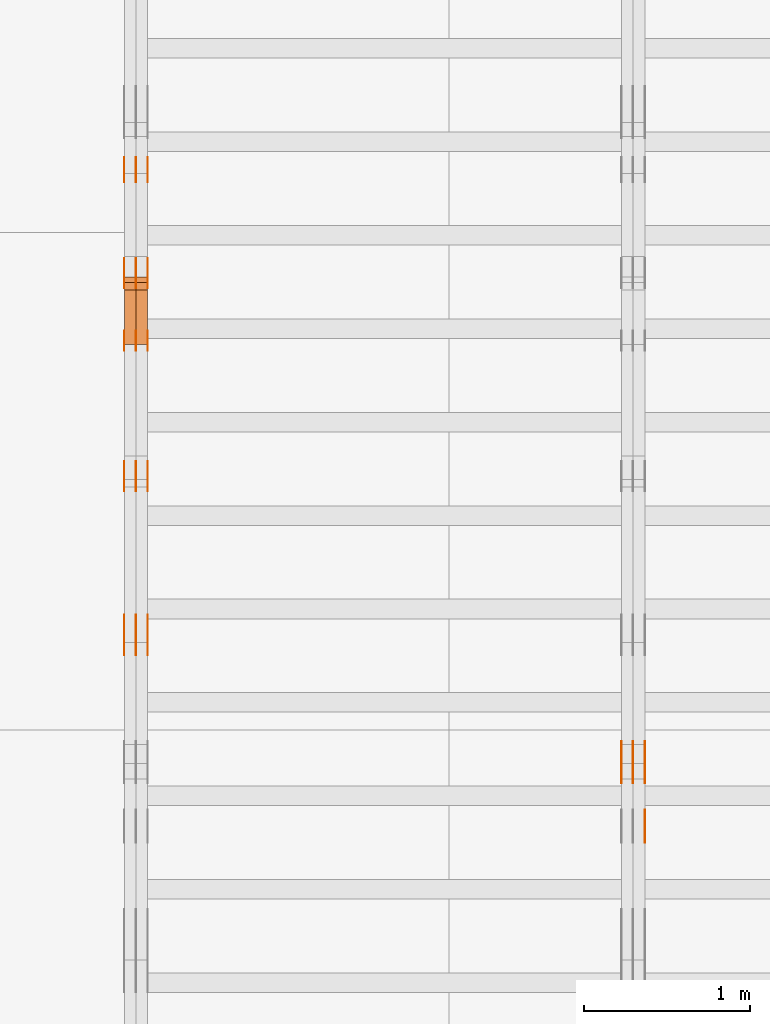
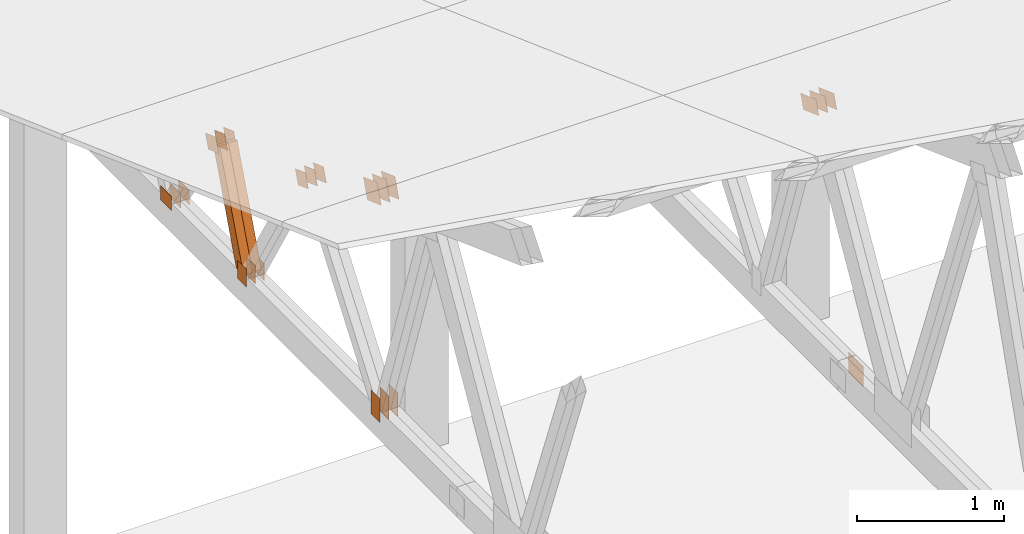
# One storey, part 111 of 189: 31 proxies.
"""IFC2X3 building model written with IfcOpenShell, lengths in millimetres."""

from ifc_helpers import new_model, entity, si_unit, converted_unit, derived_unit, direction, frame, frame_2d, origin, origin_2d_with_axis, place, context, subcontext, project, spatial, polyline, rectangle, outline, extrude, source, transform, mapped, material, type_object, type_shapes, element, save


model = new_model("IFC2X3")

# Units and contexts
model_context = context("Model", 3, precision=0.01, world=origin(), true_north=direction((6.12303176911189e-17, 1.0)))
body_context = subcontext(model_context, "Body", "Model", "MODEL_VIEW")
ifc_project = project(units=[si_unit("LENGTHUNIT", "METRE", prefix="MILLI"), si_unit("AREAUNIT", "SQUARE_METRE"), si_unit("VOLUMEUNIT", "CUBIC_METRE"), converted_unit("PLANEANGLEUNIT", "DEGREE", entity("IfcRatioMeasure", 0.0174532925199433), si_unit("PLANEANGLEUNIT", "RADIAN"), dimensions=[0, 0, 0, 0, 0, 0, 0]), si_unit("MASSUNIT", "GRAM", prefix="KILO"), derived_unit("MASSDENSITYUNIT", [(si_unit("MASSUNIT", "GRAM", prefix="KILO"), 1), (si_unit("LENGTHUNIT", "METRE"), -3)]), si_unit("TIMEUNIT", "SECOND"), si_unit("FREQUENCYUNIT", "HERTZ"), si_unit("THERMODYNAMICTEMPERATUREUNIT", "DEGREE_CELSIUS"), derived_unit("THERMALTRANSMITTANCEUNIT", [(si_unit("MASSUNIT", "GRAM", prefix="KILO"), 1), (si_unit("THERMODYNAMICTEMPERATUREUNIT", "KELVIN"), -1), (si_unit("TIMEUNIT", "SECOND"), -3)]), derived_unit("VOLUMETRICFLOWRATEUNIT", [(si_unit("LENGTHUNIT", "METRE"), 3), (si_unit("TIMEUNIT", "SECOND"), -1)]), si_unit("ELECTRICCURRENTUNIT", "AMPERE"), si_unit("ELECTRICVOLTAGEUNIT", "VOLT"), si_unit("POWERUNIT", "WATT"), si_unit("FORCEUNIT", "NEWTON"), si_unit("ILLUMINANCEUNIT", "LUX"), si_unit("LUMINOUSFLUXUNIT", "LUMEN"), si_unit("LUMINOUSINTENSITYUNIT", "CANDELA"), derived_unit("USERDEFINED", [(si_unit("MASSUNIT", "GRAM", prefix="KILO"), -1), (si_unit("LENGTHUNIT", "METRE"), -2), (si_unit("TIMEUNIT", "SECOND"), 3), (si_unit("LUMINOUSFLUXUNIT", "LUMEN"), 1)]), derived_unit("LINEARVELOCITYUNIT", [(si_unit("LENGTHUNIT", "METRE"), 1), (si_unit("TIMEUNIT", "SECOND"), -1)]), si_unit("PRESSUREUNIT", "PASCAL"), derived_unit("USERDEFINED", [(si_unit("LENGTHUNIT", "METRE"), -2), (si_unit("MASSUNIT", "GRAM", prefix="KILO"), 1), (si_unit("TIMEUNIT", "SECOND"), -2)])], contexts=[model_context])

# Site, building, storey
site_placement = place(None, origin())
site = spatial("IfcSite", under=ifc_project, at=site_placement, CompositionType="ELEMENT")
building_placement = place(site_placement, origin())
building = spatial("IfcBuilding", under=site, at=building_placement, CompositionType="ELEMENT")
storey_placement = place(building_placement, origin())
storey = spatial("IfcBuildingStorey", under=building, at=storey_placement, Name="Default", CompositionType="ELEMENT", Elevation=0.0)

# Proxies
ifc_material_1 = material(Name="IfcSurfaceStyle #27528")
building_element_proxy_type_1 = type_object("IfcBuildingElementProxyType", PredefinedType="NOTDEFINED", material=ifc_material_1)
shared_shape_1 = source(origin(), body_context, "Body", "SweptSolid", [
    extrude(outline(polyline([(-112.499846801582, -59.999986193028), (112.499924372729, -59.999986193028), (112.499888552087, 59.999986193028), (-112.499966123235, 59.999986193028), (-112.499846801582, -59.999986193028)])), frame((112.499989807712, 60.0001003787081, 0.0), z_axis=(0.0, 0.0, 1.0), x_axis=(-1.0, 0.0, 0.0)), (0.0, 0.0, 1.0), 1.3),
])
type_shapes(building_element_proxy_type_1, [shared_shape_1])
proxy_1_placement = place(building_placement, frame((3336.3, 24040.8868138992, 2049.61031693104), z_axis=(-1.0, 0.0, 0.0), x_axis=(0.0, -0.939692620785908, 0.342020143325669)))
element("IfcBuildingElementProxy", 1, at=proxy_1_placement, inside=storey, type_object=building_element_proxy_type_1, material=ifc_material_1, context=body_context, shape_type="MappedRepresentation", body=[
    mapped(shared_shape_1, transform((0.0, 0.0, 0.0), scale=1.0)),
])
ifc_material_2 = material(Name="IfcSurfaceStyle #27471")
building_element_proxy_type_2 = type_object("IfcBuildingElementProxyType", PredefinedType="NOTDEFINED", material=ifc_material_2)
shared_shape_2 = source(origin(), body_context, "Body", "SweptSolid", [
    extrude(outline(polyline([(-112.499846801582, -59.999986193028), (112.499924372729, -59.999986193028), (112.499888552087, 59.999986193028), (-112.499966123235, 59.999986193028), (-112.499846801582, -59.999986193028)])), frame((112.499989807712, 60.0001003787081, 0.0), z_axis=(0.0, 0.0, 1.0), x_axis=(-1.0, 0.0, 0.0)), (0.0, 0.0, 1.0), 1.29999999999998),
])
type_shapes(building_element_proxy_type_2, [shared_shape_2])
proxy_2_placement = place(building_placement, frame((3265.0, 24040.8868138992, 2049.61031693104), z_axis=(-1.0, 0.0, 0.0), x_axis=(0.0, -0.939692620785908, 0.342020143325669)))
element("IfcBuildingElementProxy", 2, at=proxy_2_placement, inside=storey, type_object=building_element_proxy_type_2, material=ifc_material_2, context=body_context, shape_type="MappedRepresentation", body=[
    mapped(shared_shape_2, transform((0.0, 0.0, 0.0), scale=1.0)),
])
ifc_material_3 = material(Name="IfcSurfaceStyle #27414")
building_element_proxy_type_3 = type_object("IfcBuildingElementProxyType", PredefinedType="NOTDEFINED", material=ifc_material_3)
shared_shape_3 = source(origin(), body_context, "Body", "SweptSolid", [
    extrude(outline(polyline([(-112.499846801582, -59.999986193028), (112.499924372729, -59.999986193028), (112.499888552087, 59.999986193028), (-112.499966123235, 59.999986193028), (-112.499846801582, -59.999986193028)])), frame((112.499989807712, 60.0001003787081, 0.0), z_axis=(0.0, 0.0, 1.0), x_axis=(-1.0, 0.0, 0.0)), (0.0, 0.0, 1.0), 1.29999999999998),
])
type_shapes(building_element_proxy_type_3, [shared_shape_3])
proxy_3_placement = place(building_placement, frame((3266.3, 24040.8868138992, 2049.61031693104), z_axis=(-1.0, 0.0, 0.0), x_axis=(0.0, -0.939692620785908, 0.342020143325669)))
element("IfcBuildingElementProxy", 3, at=proxy_3_placement, inside=storey, type_object=building_element_proxy_type_3, material=ifc_material_3, context=body_context, shape_type="MappedRepresentation", body=[
    mapped(shared_shape_3, transform((0.0, 0.0, 0.0), scale=1.0)),
])
ifc_material_4 = material(Name="IfcSurfaceStyle #27357")
building_element_proxy_type_4 = type_object("IfcBuildingElementProxyType", PredefinedType="NOTDEFINED", material=ifc_material_4)
shared_shape_4 = source(origin(), body_context, "Body", "SweptSolid", [
    extrude(outline(polyline([(-112.499846801582, -59.999986193028), (112.499924372729, -59.999986193028), (112.499888552087, 59.999986193028), (-112.499966123235, 59.999986193028), (-112.499846801582, -59.999986193028)])), frame((112.499989807712, 60.0001003787081, 0.0), z_axis=(0.0, 0.0, 1.0), x_axis=(-1.0, 0.0, 0.0)), (0.0, 0.0, 1.0), 1.29999999999999),
])
type_shapes(building_element_proxy_type_4, [shared_shape_4])
proxy_4_placement = place(building_placement, frame((3195.0, 24040.8868138992, 2049.61031693104), z_axis=(-1.0, 0.0, 0.0), x_axis=(0.0, -0.939692620785908, 0.342020143325669)))
element("IfcBuildingElementProxy", 4, at=proxy_4_placement, inside=storey, type_object=building_element_proxy_type_4, material=ifc_material_4, context=body_context, shape_type="MappedRepresentation", body=[
    mapped(shared_shape_4, transform((0.0, 0.0, 0.0), scale=1.0)),
])
ifc_material_5 = material(Name="IfcSurfaceStyle #23652")
building_element_proxy_type_5 = type_object("IfcBuildingElementProxyType", PredefinedType="NOTDEFINED", material=ifc_material_5)
shared_shape_5 = source(origin(), body_context, "Body", "SweptSolid", [
    extrude(rectangle(XDim=200.0, YDim=168.0, at=origin_2d_with_axis()), frame((100.0, 84.0, 0.0), z_axis=(0.0, 0.0, 1.0), x_axis=(-1.0, 0.0, 0.0)), (0.0, 0.0, 1.0), 1.3),
])
type_shapes(building_element_proxy_type_5, [shared_shape_5])
proxy_5_placement = place(building_placement, frame((3336.3, 23470.0, 206.5), z_axis=(-1.0, 0.0, 0.0), x_axis=(0.0, 1.0, 0.0)))
element("IfcBuildingElementProxy", 5, at=proxy_5_placement, inside=storey, type_object=building_element_proxy_type_5, material=ifc_material_5, context=body_context, shape_type="MappedRepresentation", body=[
    mapped(shared_shape_5, transform((0.0, 0.0, 0.0), scale=1.0)),
])
ifc_material_6 = material(Name="IfcSurfaceStyle #11507")
building_element_proxy_type_6 = type_object("IfcBuildingElementProxyType", PredefinedType="NOTDEFINED", material=ifc_material_6)
shared_shape_6 = source(origin(), body_context, "Body", "SweptSolid", [
    extrude(rectangle(XDim=200.0, YDim=120.0, at=origin_2d_with_axis()), frame((100.0, 60.0002296775929, 0.0), z_axis=(0.0, 0.0, 1.0), x_axis=(-1.0, 0.0, 0.0)), (0.0, 0.0, 1.0), 1.3),
])
type_shapes(building_element_proxy_type_6, [shared_shape_6])
proxy_6_placement = place(building_placement, frame((336.3, 24619.3435203224, 145.0), z_axis=(-1.0, 0.0, 0.0), x_axis=(0.0, 0.0, 1.0)))
element("IfcBuildingElementProxy", 6, at=proxy_6_placement, inside=storey, type_object=building_element_proxy_type_6, material=ifc_material_6, context=body_context, shape_type="MappedRepresentation", body=[
    mapped(shared_shape_6, transform((0.0, 0.0, 0.0), scale=1.0)),
])
ifc_material_7 = material(Name="IfcSurfaceStyle #11450")
building_element_proxy_type_7 = type_object("IfcBuildingElementProxyType", PredefinedType="NOTDEFINED", material=ifc_material_7)
shared_shape_7 = source(origin(), body_context, "Body", "SweptSolid", [
    extrude(rectangle(XDim=200.0, YDim=120.0, at=origin_2d_with_axis()), frame((100.0, 60.0002296775929, 0.0), z_axis=(0.0, 0.0, 1.0), x_axis=(-1.0, 0.0, 0.0)), (0.0, 0.0, 1.0), 1.29999999999998),
])
type_shapes(building_element_proxy_type_7, [shared_shape_7])
proxy_7_placement = place(building_placement, frame((265.0, 24619.3435203224, 145.0), z_axis=(-1.0, 0.0, 0.0), x_axis=(0.0, 0.0, 1.0)))
element("IfcBuildingElementProxy", 7, at=proxy_7_placement, inside=storey, type_object=building_element_proxy_type_7, material=ifc_material_7, context=body_context, shape_type="MappedRepresentation", body=[
    mapped(shared_shape_7, transform((0.0, 0.0, 0.0), scale=1.0)),
])
ifc_material_8 = material(Name="IfcSurfaceStyle #11393")
building_element_proxy_type_8 = type_object("IfcBuildingElementProxyType", PredefinedType="NOTDEFINED", material=ifc_material_8)
shared_shape_8 = source(origin(), body_context, "Body", "SweptSolid", [
    extrude(rectangle(XDim=200.0, YDim=120.0, at=origin_2d_with_axis()), frame((100.0, 60.0002296775929, 0.0), z_axis=(0.0, 0.0, 1.0), x_axis=(-1.0, 0.0, 0.0)), (0.0, 0.0, 1.0), 1.29999999999998),
])
type_shapes(building_element_proxy_type_8, [shared_shape_8])
proxy_8_placement = place(building_placement, frame((266.3, 24619.3435203224, 145.0), z_axis=(-1.0, 0.0, 0.0), x_axis=(0.0, 0.0, 1.0)))
element("IfcBuildingElementProxy", 8, at=proxy_8_placement, inside=storey, type_object=building_element_proxy_type_8, material=ifc_material_8, context=body_context, shape_type="MappedRepresentation", body=[
    mapped(shared_shape_8, transform((0.0, 0.0, 0.0), scale=1.0)),
])
ifc_material_9 = material(Name="IfcSurfaceStyle #11336")
building_element_proxy_type_9 = type_object("IfcBuildingElementProxyType", PredefinedType="NOTDEFINED", material=ifc_material_9)
shared_shape_9 = source(origin(), body_context, "Body", "SweptSolid", [
    extrude(rectangle(XDim=200.0, YDim=120.0, at=origin_2d_with_axis()), frame((100.0, 60.0002296775929, 0.0), z_axis=(0.0, 0.0, 1.0), x_axis=(-1.0, 0.0, 0.0)), (0.0, 0.0, 1.0), 1.29999999999999),
])
type_shapes(building_element_proxy_type_9, [shared_shape_9])
proxy_9_placement = place(building_placement, frame((195.0, 24619.3435203224, 145.0), z_axis=(-1.0, 0.0, 0.0), x_axis=(0.0, 0.0, 1.0)))
element("IfcBuildingElementProxy", 9, at=proxy_9_placement, inside=storey, type_object=building_element_proxy_type_9, material=ifc_material_9, context=body_context, shape_type="MappedRepresentation", body=[
    mapped(shared_shape_9, transform((0.0, 0.0, 0.0), scale=1.0)),
])
ifc_material_10 = material(Name="IfcSurfaceStyle #10823")
building_element_proxy_type_10 = type_object("IfcBuildingElementProxyType", PredefinedType="NOTDEFINED", material=ifc_material_10)
shared_shape_10 = source(origin(), body_context, "Body", "SweptSolid", [
    extrude(outline(polyline([(-74.9999475298494, -60.0), (75.0000042257432, -60.0), (74.9999684051025, 60.0), (-75.0000251009963, 60.0), (-74.9999475298494, -60.0)])), frame((75.0000607644577, 60.0000865490217, 0.0), z_axis=(0.0, 0.0, 1.0), x_axis=(-1.0, 0.0, 0.0)), (0.0, 0.0, 1.0), 1.3),
])
type_shapes(building_element_proxy_type_10, [shared_shape_10])
proxy_10_placement = place(building_placement, frame((336.3, 25732.0586805394, 1446.84420669249), z_axis=(-1.0, 0.0, 0.0), x_axis=(0.0, -0.939692620785908, 0.342020143325669)))
element("IfcBuildingElementProxy", 10, at=proxy_10_placement, inside=storey, type_object=building_element_proxy_type_10, material=ifc_material_10, context=body_context, shape_type="MappedRepresentation", body=[
    mapped(shared_shape_10, transform((0.0, 0.0, 0.0), scale=1.0)),
])
ifc_material_11 = material(Name="IfcSurfaceStyle #10766")
building_element_proxy_type_11 = type_object("IfcBuildingElementProxyType", PredefinedType="NOTDEFINED", material=ifc_material_11)
shared_shape_11 = source(origin(), body_context, "Body", "SweptSolid", [
    extrude(outline(polyline([(-74.9999475298494, -60.0), (75.0000042257432, -60.0), (74.9999684051025, 60.0), (-75.0000251009963, 60.0), (-74.9999475298494, -60.0)])), frame((75.0000607644577, 60.0000865490217, 0.0), z_axis=(0.0, 0.0, 1.0), x_axis=(-1.0, 0.0, 0.0)), (0.0, 0.0, 1.0), 1.29999999999999),
])
type_shapes(building_element_proxy_type_11, [shared_shape_11])
proxy_11_placement = place(building_placement, frame((265.0, 25732.0586805394, 1446.84420669249), z_axis=(-1.0, 0.0, 0.0), x_axis=(0.0, -0.939692620785908, 0.342020143325669)))
element("IfcBuildingElementProxy", 11, at=proxy_11_placement, inside=storey, type_object=building_element_proxy_type_11, material=ifc_material_11, context=body_context, shape_type="MappedRepresentation", body=[
    mapped(shared_shape_11, transform((0.0, 0.0, 0.0), scale=1.0)),
])
ifc_material_12 = material(Name="IfcSurfaceStyle #10709")
building_element_proxy_type_12 = type_object("IfcBuildingElementProxyType", PredefinedType="NOTDEFINED", material=ifc_material_12)
shared_shape_12 = source(origin(), body_context, "Body", "SweptSolid", [
    extrude(outline(polyline([(-74.9999475298494, -60.0), (75.0000042257432, -60.0), (74.9999684051025, 60.0), (-75.0000251009963, 60.0), (-74.9999475298494, -60.0)])), frame((75.0000607644577, 60.0000865490217, 0.0), z_axis=(0.0, 0.0, 1.0), x_axis=(-1.0, 0.0, 0.0)), (0.0, 0.0, 1.0), 1.29999999999999),
])
type_shapes(building_element_proxy_type_12, [shared_shape_12])
proxy_12_placement = place(building_placement, frame((266.3, 25732.0586805394, 1446.84420669249), z_axis=(-1.0, 0.0, 0.0), x_axis=(0.0, -0.939692620785908, 0.342020143325669)))
element("IfcBuildingElementProxy", 12, at=proxy_12_placement, inside=storey, type_object=building_element_proxy_type_12, material=ifc_material_12, context=body_context, shape_type="MappedRepresentation", body=[
    mapped(shared_shape_12, transform((0.0, 0.0, 0.0), scale=1.0)),
])
ifc_material_13 = material(Name="IfcSurfaceStyle #10652")
building_element_proxy_type_13 = type_object("IfcBuildingElementProxyType", PredefinedType="NOTDEFINED", material=ifc_material_13)
shared_shape_13 = source(origin(), body_context, "Body", "SweptSolid", [
    extrude(outline(polyline([(-74.9999475298494, -60.0), (75.0000042257432, -60.0), (74.9999684051025, 60.0), (-75.0000251009963, 60.0), (-74.9999475298494, -60.0)])), frame((75.0000607644577, 60.0000865490217, 0.0), z_axis=(0.0, 0.0, 1.0), x_axis=(-1.0, 0.0, 0.0)), (0.0, 0.0, 1.0), 1.29999999999999),
])
type_shapes(building_element_proxy_type_13, [shared_shape_13])
proxy_13_placement = place(building_placement, frame((195.0, 25732.0586805394, 1446.84420669249), z_axis=(-1.0, 0.0, 0.0), x_axis=(0.0, -0.939692620785908, 0.342020143325669)))
element("IfcBuildingElementProxy", 13, at=proxy_13_placement, inside=storey, type_object=building_element_proxy_type_13, material=ifc_material_13, context=body_context, shape_type="MappedRepresentation", body=[
    mapped(shared_shape_13, transform((0.0, 0.0, 0.0), scale=1.0)),
])
ifc_material_14 = material(Name="IfcSurfaceStyle #10595")
building_element_proxy_type_14 = type_object("IfcBuildingElementProxyType", PredefinedType="NOTDEFINED", material=ifc_material_14)
shared_shape_14 = source(origin(), body_context, "Body", "SweptSolid", [
    extrude(rectangle(XDim=150.0, YDim=120.0, at=frame_2d((-7.105427357601e-15, 0.0), x_axis=(1.0, 0.0))), frame((75.0, 60.0, 0.0), z_axis=(0.0, 0.0, 1.0), x_axis=(-1.0, 0.0, 0.0)), (0.0, 0.0, 1.0), 1.3),
])
type_shapes(building_element_proxy_type_14, [shared_shape_14])
proxy_14_placement = place(building_placement, frame((336.3, 26439.0083007813, 170.0), z_axis=(-1.0, 0.0, 0.0), x_axis=(0.0, 0.0, 1.0)))
element("IfcBuildingElementProxy", 14, at=proxy_14_placement, inside=storey, type_object=building_element_proxy_type_14, material=ifc_material_14, context=body_context, shape_type="MappedRepresentation", body=[
    mapped(shared_shape_14, transform((0.0, 0.0, 0.0), scale=1.0)),
])
ifc_material_15 = material(Name="IfcSurfaceStyle #10538")
building_element_proxy_type_15 = type_object("IfcBuildingElementProxyType", PredefinedType="NOTDEFINED", material=ifc_material_15)
shared_shape_15 = source(origin(), body_context, "Body", "SweptSolid", [
    extrude(rectangle(XDim=150.0, YDim=120.0, at=frame_2d((-7.105427357601e-15, 0.0), x_axis=(1.0, 0.0))), frame((75.0, 60.0, 0.0), z_axis=(0.0, 0.0, 1.0), x_axis=(-1.0, 0.0, 0.0)), (0.0, 0.0, 1.0), 1.29999999999999),
])
type_shapes(building_element_proxy_type_15, [shared_shape_15])
proxy_15_placement = place(building_placement, frame((265.0, 26439.0083007813, 170.0), z_axis=(-1.0, 0.0, 0.0), x_axis=(0.0, 0.0, 1.0)))
element("IfcBuildingElementProxy", 15, at=proxy_15_placement, inside=storey, type_object=building_element_proxy_type_15, material=ifc_material_15, context=body_context, shape_type="MappedRepresentation", body=[
    mapped(shared_shape_15, transform((0.0, 0.0, 0.0), scale=1.0)),
])
ifc_material_16 = material(Name="IfcSurfaceStyle #10481")
building_element_proxy_type_16 = type_object("IfcBuildingElementProxyType", PredefinedType="NOTDEFINED", material=ifc_material_16)
shared_shape_16 = source(origin(), body_context, "Body", "SweptSolid", [
    extrude(rectangle(XDim=150.0, YDim=120.0, at=frame_2d((-7.105427357601e-15, 0.0), x_axis=(1.0, 0.0))), frame((75.0, 60.0, 0.0), z_axis=(0.0, 0.0, 1.0), x_axis=(-1.0, 0.0, 0.0)), (0.0, 0.0, 1.0), 1.29999999999999),
])
type_shapes(building_element_proxy_type_16, [shared_shape_16])
proxy_16_placement = place(building_placement, frame((266.3, 26439.0083007813, 170.0), z_axis=(-1.0, 0.0, 0.0), x_axis=(0.0, 0.0, 1.0)))
element("IfcBuildingElementProxy", 16, at=proxy_16_placement, inside=storey, type_object=building_element_proxy_type_16, material=ifc_material_16, context=body_context, shape_type="MappedRepresentation", body=[
    mapped(shared_shape_16, transform((0.0, 0.0, 0.0), scale=1.0)),
])
ifc_material_17 = material(Name="IfcSurfaceStyle #10424")
building_element_proxy_type_17 = type_object("IfcBuildingElementProxyType", PredefinedType="NOTDEFINED", material=ifc_material_17)
shared_shape_17 = source(origin(), body_context, "Body", "SweptSolid", [
    extrude(rectangle(XDim=150.0, YDim=120.0, at=frame_2d((-7.105427357601e-15, 0.0), x_axis=(1.0, 0.0))), frame((75.0, 60.0, 0.0), z_axis=(0.0, 0.0, 1.0), x_axis=(-1.0, 0.0, 0.0)), (0.0, 0.0, 1.0), 1.29999999999999),
])
type_shapes(building_element_proxy_type_17, [shared_shape_17])
proxy_17_placement = place(building_placement, frame((195.0, 26439.0083007813, 170.0), z_axis=(-1.0, 0.0, 0.0), x_axis=(0.0, 0.0, 1.0)))
element("IfcBuildingElementProxy", 17, at=proxy_17_placement, inside=storey, type_object=building_element_proxy_type_17, material=ifc_material_17, context=body_context, shape_type="MappedRepresentation", body=[
    mapped(shared_shape_17, transform((0.0, 0.0, 0.0), scale=1.0)),
])
ifc_material_18 = material(Name="IfcSurfaceStyle #9911")
building_element_proxy_type_18 = type_object("IfcBuildingElementProxyType", PredefinedType="NOTDEFINED", material=ifc_material_18)
shared_shape_18 = source(origin(), body_context, "Body", "SweptSolid", [
    extrude(outline(polyline([(-74.9999684051023, -60.0), (75.0000251009964, -60.0), (74.9999475298495, 60.0), (-75.0000042257435, 60.0), (-74.9999684051023, -60.0)])), frame((75.0000251009964, 60.0000006265238, 0.0), z_axis=(0.0, 0.0, 1.0), x_axis=(-1.0, 0.0, 0.0)), (0.0, 0.0, 1.0), 1.3),
])
type_shapes(building_element_proxy_type_18, [shared_shape_18])
proxy_18_placement = place(building_placement, frame((336.3, 26956.490053282, 1001.18769055967), z_axis=(-1.0, 0.0, 0.0), x_axis=(0.0, -0.939692620785908, 0.342020143325669)))
element("IfcBuildingElementProxy", 18, at=proxy_18_placement, inside=storey, type_object=building_element_proxy_type_18, material=ifc_material_18, context=body_context, shape_type="MappedRepresentation", body=[
    mapped(shared_shape_18, transform((0.0, 0.0, 0.0), scale=1.0)),
])
ifc_material_19 = material(Name="IfcSurfaceStyle #9854")
building_element_proxy_type_19 = type_object("IfcBuildingElementProxyType", PredefinedType="NOTDEFINED", material=ifc_material_19)
shared_shape_19 = source(origin(), body_context, "Body", "SweptSolid", [
    extrude(outline(polyline([(-74.9999684051023, -60.0), (75.0000251009964, -60.0), (74.9999475298495, 60.0), (-75.0000042257435, 60.0), (-74.9999684051023, -60.0)])), frame((75.0000251009964, 60.0000006265238, 0.0), z_axis=(0.0, 0.0, 1.0), x_axis=(-1.0, 0.0, 0.0)), (0.0, 0.0, 1.0), 1.29999999999999),
])
type_shapes(building_element_proxy_type_19, [shared_shape_19])
proxy_19_placement = place(building_placement, frame((265.0, 26956.490053282, 1001.18769055967), z_axis=(-1.0, 0.0, 0.0), x_axis=(0.0, -0.939692620785908, 0.342020143325669)))
element("IfcBuildingElementProxy", 19, at=proxy_19_placement, inside=storey, type_object=building_element_proxy_type_19, material=ifc_material_19, context=body_context, shape_type="MappedRepresentation", body=[
    mapped(shared_shape_19, transform((0.0, 0.0, 0.0), scale=1.0)),
])
ifc_material_20 = material(Name="IfcSurfaceStyle #9797")
building_element_proxy_type_20 = type_object("IfcBuildingElementProxyType", PredefinedType="NOTDEFINED", material=ifc_material_20)
shared_shape_20 = source(origin(), body_context, "Body", "SweptSolid", [
    extrude(outline(polyline([(-74.9999684051023, -60.0), (75.0000251009964, -60.0), (74.9999475298495, 60.0), (-75.0000042257435, 60.0), (-74.9999684051023, -60.0)])), frame((75.0000251009964, 60.0000006265238, 0.0), z_axis=(0.0, 0.0, 1.0), x_axis=(-1.0, 0.0, 0.0)), (0.0, 0.0, 1.0), 1.29999999999999),
])
type_shapes(building_element_proxy_type_20, [shared_shape_20])
proxy_20_placement = place(building_placement, frame((266.3, 26956.490053282, 1001.18769055967), z_axis=(-1.0, 0.0, 0.0), x_axis=(0.0, -0.939692620785908, 0.342020143325669)))
element("IfcBuildingElementProxy", 20, at=proxy_20_placement, inside=storey, type_object=building_element_proxy_type_20, material=ifc_material_20, context=body_context, shape_type="MappedRepresentation", body=[
    mapped(shared_shape_20, transform((0.0, 0.0, 0.0), scale=1.0)),
])
ifc_material_21 = material(Name="IfcSurfaceStyle #9740")
building_element_proxy_type_21 = type_object("IfcBuildingElementProxyType", PredefinedType="NOTDEFINED", material=ifc_material_21)
shared_shape_21 = source(origin(), body_context, "Body", "SweptSolid", [
    extrude(outline(polyline([(-74.9999684051023, -60.0), (75.0000251009964, -60.0), (74.9999475298495, 60.0), (-75.0000042257435, 60.0), (-74.9999684051023, -60.0)])), frame((75.0000251009964, 60.0000006265238, 0.0), z_axis=(0.0, 0.0, 1.0), x_axis=(-1.0, 0.0, 0.0)), (0.0, 0.0, 1.0), 1.29999999999999),
])
type_shapes(building_element_proxy_type_21, [shared_shape_21])
proxy_21_placement = place(building_placement, frame((195.0, 26956.490053282, 1001.18769055967), z_axis=(-1.0, 0.0, 0.0), x_axis=(0.0, -0.939692620785908, 0.342020143325669)))
element("IfcBuildingElementProxy", 21, at=proxy_21_placement, inside=storey, type_object=building_element_proxy_type_21, material=ifc_material_21, context=body_context, shape_type="MappedRepresentation", body=[
    mapped(shared_shape_21, transform((0.0, 0.0, 0.0), scale=1.0)),
])
ifc_material_22 = material(Name="IfcSurfaceStyle #9683")
building_element_proxy_type_22 = type_object("IfcBuildingElementProxyType", PredefinedType="NOTDEFINED", material=ifc_material_22)
shared_shape_22 = source(origin(), body_context, "Body", "SweptSolid", [
    extrude(rectangle(XDim=150.0, YDim=120.0, at=origin_2d_with_axis()), frame((75.0, 60.0, 0.0), z_axis=(0.0, 0.0, 1.0), x_axis=(-1.0, 0.0, 0.0)), (0.0, 0.0, 1.0), 1.3),
])
type_shapes(building_element_proxy_type_22, [shared_shape_22])
proxy_22_placement = place(building_placement, frame((336.3, 27607.3129882813, 185.0), z_axis=(-1.0, 0.0, 0.0), x_axis=(0.0, -1.0, 0.0)))
element("IfcBuildingElementProxy", 22, at=proxy_22_placement, inside=storey, type_object=building_element_proxy_type_22, material=ifc_material_22, context=body_context, shape_type="MappedRepresentation", body=[
    mapped(shared_shape_22, transform((0.0, 0.0, 0.0), scale=1.0)),
])
ifc_material_23 = material(Name="IfcSurfaceStyle #9626")
building_element_proxy_type_23 = type_object("IfcBuildingElementProxyType", PredefinedType="NOTDEFINED", material=ifc_material_23)
shared_shape_23 = source(origin(), body_context, "Body", "SweptSolid", [
    extrude(rectangle(XDim=150.0, YDim=120.0, at=origin_2d_with_axis()), frame((75.0, 60.0, 0.0), z_axis=(0.0, 0.0, 1.0), x_axis=(-1.0, 0.0, 0.0)), (0.0, 0.0, 1.0), 1.29999999999999),
])
type_shapes(building_element_proxy_type_23, [shared_shape_23])
proxy_23_placement = place(building_placement, frame((265.0, 27607.3129882813, 185.0), z_axis=(-1.0, 0.0, 0.0), x_axis=(0.0, -1.0, 0.0)))
element("IfcBuildingElementProxy", 23, at=proxy_23_placement, inside=storey, type_object=building_element_proxy_type_23, material=ifc_material_23, context=body_context, shape_type="MappedRepresentation", body=[
    mapped(shared_shape_23, transform((0.0, 0.0, 0.0), scale=1.0)),
])
ifc_material_24 = material(Name="IfcSurfaceStyle #9569")
building_element_proxy_type_24 = type_object("IfcBuildingElementProxyType", PredefinedType="NOTDEFINED", material=ifc_material_24)
shared_shape_24 = source(origin(), body_context, "Body", "SweptSolid", [
    extrude(rectangle(XDim=150.0, YDim=120.0, at=origin_2d_with_axis()), frame((75.0, 60.0, 0.0), z_axis=(0.0, 0.0, 1.0), x_axis=(-1.0, 0.0, 0.0)), (0.0, 0.0, 1.0), 1.29999999999999),
])
type_shapes(building_element_proxy_type_24, [shared_shape_24])
proxy_24_placement = place(building_placement, frame((266.3, 27607.3129882813, 185.0), z_axis=(-1.0, 0.0, 0.0), x_axis=(0.0, -1.0, 0.0)))
element("IfcBuildingElementProxy", 24, at=proxy_24_placement, inside=storey, type_object=building_element_proxy_type_24, material=ifc_material_24, context=body_context, shape_type="MappedRepresentation", body=[
    mapped(shared_shape_24, transform((0.0, 0.0, 0.0), scale=1.0)),
])
ifc_material_25 = material(Name="IfcSurfaceStyle #9512")
building_element_proxy_type_25 = type_object("IfcBuildingElementProxyType", PredefinedType="NOTDEFINED", material=ifc_material_25)
shared_shape_25 = source(origin(), body_context, "Body", "SweptSolid", [
    extrude(rectangle(XDim=150.0, YDim=120.0, at=origin_2d_with_axis()), frame((75.0, 60.0, 0.0), z_axis=(0.0, 0.0, 1.0), x_axis=(-1.0, 0.0, 0.0)), (0.0, 0.0, 1.0), 1.29999999999999),
])
type_shapes(building_element_proxy_type_25, [shared_shape_25])
proxy_25_placement = place(building_placement, frame((195.0, 27607.3129882813, 185.0), z_axis=(-1.0, 0.0, 0.0), x_axis=(0.0, -1.0, 0.0)))
element("IfcBuildingElementProxy", 25, at=proxy_25_placement, inside=storey, type_object=building_element_proxy_type_25, material=ifc_material_25, context=body_context, shape_type="MappedRepresentation", body=[
    mapped(shared_shape_25, transform((0.0, 0.0, 0.0), scale=1.0)),
])
ifc_material_26 = material(Name="IfcSurfaceStyle #5699")
building_element_proxy_type_26 = type_object("IfcBuildingElementProxyType", PredefinedType="NOTDEFINED", material=ifc_material_26)
shared_shape_26 = source(origin(), body_context, "Body", "SweptSolid", [
    extrude(outline(polyline([(-99.9999065788418, -84.0000755647729), (99.9999734279406, -84.0000755647729), (99.9999483293475, 84.000075564773), (-100.000015178446, 84.000075564773), (-99.9999065788418, -84.0000755647729)])), frame((100.000157783747, 84.0001144608011, 0.0), z_axis=(0.0, 0.0, 1.0), x_axis=(-1.0, 0.0, 0.0)), (0.0, 0.0, 1.0), 1.3),
])
type_shapes(building_element_proxy_type_26, [shared_shape_26])
proxy_26_placement = place(building_placement, frame((336.3, 24788.4767593228, 1895.10136879206), z_axis=(-1.0, 0.0, 0.0), x_axis=(0.0, -0.939692620785908, 0.342020143325669)))
element("IfcBuildingElementProxy", 26, at=proxy_26_placement, inside=storey, type_object=building_element_proxy_type_26, material=ifc_material_26, context=body_context, shape_type="MappedRepresentation", body=[
    mapped(shared_shape_26, transform((0.0, 0.0, 0.0), scale=1.0)),
])
ifc_material_27 = material(Name="IfcSurfaceStyle #5642")
building_element_proxy_type_27 = type_object("IfcBuildingElementProxyType", PredefinedType="NOTDEFINED", material=ifc_material_27)
shared_shape_27 = source(origin(), body_context, "Body", "SweptSolid", [
    extrude(outline(polyline([(-99.9999065788418, -84.0000755647729), (99.9999734279406, -84.0000755647729), (99.9999483293475, 84.000075564773), (-100.000015178446, 84.000075564773), (-99.9999065788418, -84.0000755647729)])), frame((100.000157783747, 84.0001144608011, 0.0), z_axis=(0.0, 0.0, 1.0), x_axis=(-1.0, 0.0, 0.0)), (0.0, 0.0, 1.0), 1.29999999999998),
])
type_shapes(building_element_proxy_type_27, [shared_shape_27])
proxy_27_placement = place(building_placement, frame((265.0, 24788.4767593228, 1895.10136879206), z_axis=(-1.0, 0.0, 0.0), x_axis=(0.0, -0.939692620785908, 0.342020143325669)))
element("IfcBuildingElementProxy", 27, at=proxy_27_placement, inside=storey, type_object=building_element_proxy_type_27, material=ifc_material_27, context=body_context, shape_type="MappedRepresentation", body=[
    mapped(shared_shape_27, transform((0.0, 0.0, 0.0), scale=1.0)),
])
ifc_material_28 = material(Name="IfcSurfaceStyle #5585")
building_element_proxy_type_28 = type_object("IfcBuildingElementProxyType", PredefinedType="NOTDEFINED", material=ifc_material_28)
shared_shape_28 = source(origin(), body_context, "Body", "SweptSolid", [
    extrude(outline(polyline([(-99.9999065788418, -84.0000755647729), (99.9999734279406, -84.0000755647729), (99.9999483293475, 84.000075564773), (-100.000015178446, 84.000075564773), (-99.9999065788418, -84.0000755647729)])), frame((100.000157783747, 84.0001144608011, 0.0), z_axis=(0.0, 0.0, 1.0), x_axis=(-1.0, 0.0, 0.0)), (0.0, 0.0, 1.0), 1.29999999999998),
])
type_shapes(building_element_proxy_type_28, [shared_shape_28])
proxy_28_placement = place(building_placement, frame((266.3, 24788.4767593228, 1895.10136879206), z_axis=(-1.0, 0.0, 0.0), x_axis=(0.0, -0.939692620785908, 0.342020143325669)))
element("IfcBuildingElementProxy", 28, at=proxy_28_placement, inside=storey, type_object=building_element_proxy_type_28, material=ifc_material_28, context=body_context, shape_type="MappedRepresentation", body=[
    mapped(shared_shape_28, transform((0.0, 0.0, 0.0), scale=1.0)),
])
ifc_material_29 = material(Name="IfcSurfaceStyle #5528")
building_element_proxy_type_29 = type_object("IfcBuildingElementProxyType", PredefinedType="NOTDEFINED", material=ifc_material_29)
shared_shape_29 = source(origin(), body_context, "Body", "SweptSolid", [
    extrude(outline(polyline([(-99.9999065788418, -84.0000755647729), (99.9999734279406, -84.0000755647729), (99.9999483293475, 84.000075564773), (-100.000015178446, 84.000075564773), (-99.9999065788418, -84.0000755647729)])), frame((100.000157783747, 84.0001144608011, 0.0), z_axis=(0.0, 0.0, 1.0), x_axis=(-1.0, 0.0, 0.0)), (0.0, 0.0, 1.0), 1.29999999999999),
])
type_shapes(building_element_proxy_type_29, [shared_shape_29])
proxy_29_placement = place(building_placement, frame((195.0, 24788.4767593228, 1895.10136879206), z_axis=(-1.0, 0.0, 0.0), x_axis=(0.0, -0.939692620785908, 0.342020143325669)))
element("IfcBuildingElementProxy", 29, at=proxy_29_placement, inside=storey, type_object=building_element_proxy_type_29, material=ifc_material_29, context=body_context, shape_type="MappedRepresentation", body=[
    mapped(shared_shape_29, transform((0.0, 0.0, 0.0), scale=1.0)),
])
ifc_material_30 = material(Name="IfcSurfaceStyle #2435")
building_element_proxy_type_30 = type_object("IfcBuildingElementProxyType", Name="T1-W14 2433", PredefinedType="NOTDEFINED", material=ifc_material_30)
shared_shape_30 = source(origin(), body_context, "Body", "SweptSolid", [
    extrude(outline(polyline([(-561.981237417233, -47.499947472121), (373.092610496013, -47.499947472121), (373.679602940405, -4.61719047935016e-05), (341.277449358876, 47.4999705580734), (-526.068425378061, 47.4999705580734), (-561.981237417233, -47.499947472121)])), frame((373.679632439416, 47.500120814091, 0.0), z_axis=(0.0, 0.0, 1.0), x_axis=(-1.0, 0.0, 0.0)), (0.0, 0.0, 1.0), 69.9999999999999),
])
type_shapes(building_element_proxy_type_30, [shared_shape_30])
proxy_30_placement = place(building_placement, frame((335.0, 26895.4809555667, 1086.61918844835), z_axis=(-1.0, 0.0, 0.0), x_axis=(0.0, -0.353606472447933, -0.935394281916951)))
element("IfcBuildingElementProxy", 30, at=proxy_30_placement, inside=storey, type_object=building_element_proxy_type_30, material=ifc_material_30, Name="T1-W14", context=body_context, shape_type="MappedRepresentation", body=[
    mapped(shared_shape_30, transform((0.0, 0.0, 0.0), scale=1.0)),
])
ifc_material_31 = material(Name="IfcSurfaceStyle #2369")
building_element_proxy_type_31 = type_object("IfcBuildingElementProxyType", Name="T1-W14 2367", PredefinedType="NOTDEFINED", material=ifc_material_31)
shared_shape_31 = source(origin(), body_context, "Body", "SweptSolid", [
    extrude(outline(polyline([(-561.981237417233, -47.499947472121), (373.092610496013, -47.499947472121), (373.679602940405, -4.61719047935016e-05), (341.277449358876, 47.4999705580734), (-526.068425378061, 47.4999705580734), (-561.981237417233, -47.499947472121)])), frame((373.679632439416, 47.500120814091, 0.0), z_axis=(0.0, 0.0, 1.0), x_axis=(-1.0, 0.0, 0.0)), (0.0, 0.0, 1.0), 69.9999999999999),
])
type_shapes(building_element_proxy_type_31, [shared_shape_31])
proxy_31_placement = place(building_placement, frame((265.0, 26895.4809555667, 1086.61918844835), z_axis=(-1.0, 0.0, 0.0), x_axis=(0.0, -0.353606472447933, -0.935394281916951)))
element("IfcBuildingElementProxy", 31, at=proxy_31_placement, inside=storey, type_object=building_element_proxy_type_31, material=ifc_material_31, Name="T1-W14", context=body_context, shape_type="MappedRepresentation", body=[
    mapped(shared_shape_31, transform((0.0, 0.0, 0.0), scale=1.0)),
])

save(model, "model.ifc")
